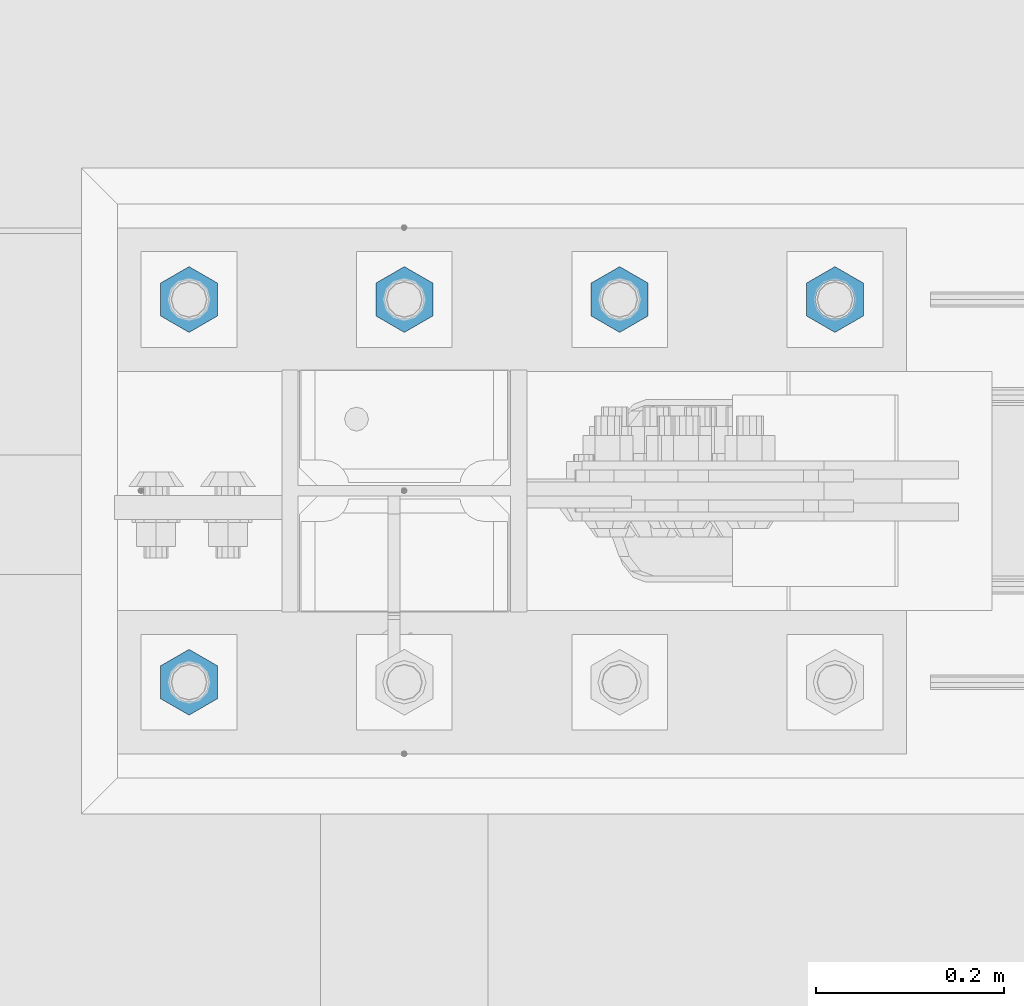
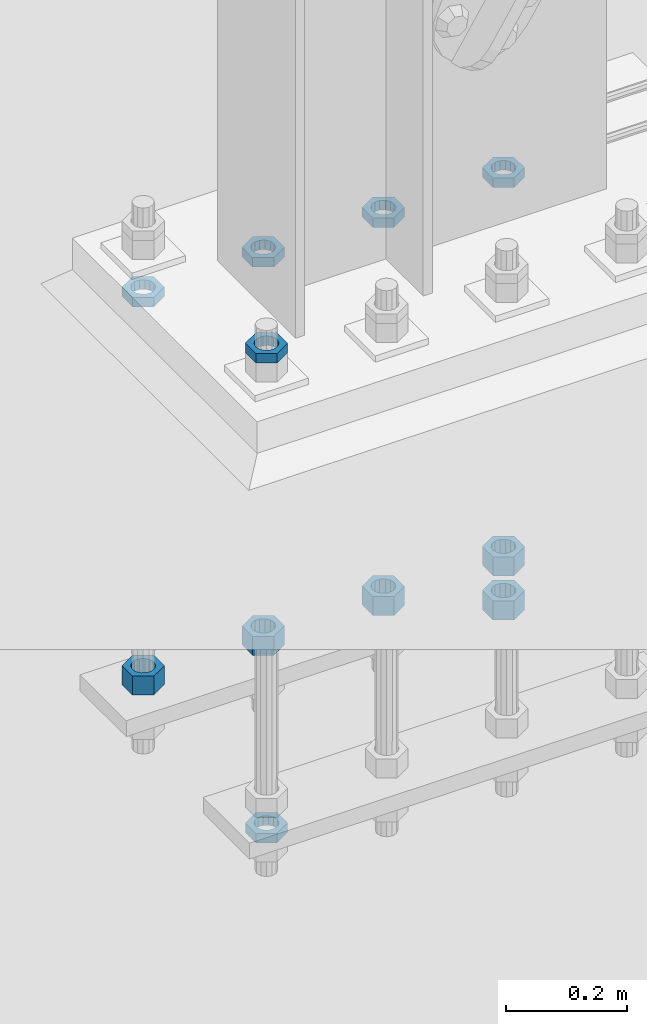
# One storey, part 2912 of 3843: 11 beams, 1 element without a shape of its own.
"""IFC2X3 building model written with IfcOpenShell, lengths in millimetres."""

from ifc_helpers import new_model, si_unit, frame, origin_with_axes, place, context, subcontext, project, spatial, faceted_brep, material, type_object, element, aggregate, save


model = new_model("IFC2X3")

# Units and contexts
model_context = context("Model", 3, precision=1e-05, world=origin_with_axes())
body_context = subcontext(model_context, "Body", "Model", "MODEL_VIEW")
ifc_project = project(units=[si_unit("LENGTHUNIT", "METRE", prefix="MILLI"), si_unit("AREAUNIT", "SQUARE_METRE"), si_unit("VOLUMEUNIT", "CUBIC_METRE"), si_unit("MASSUNIT", "GRAM", prefix="KILO"), si_unit("TIMEUNIT", "SECOND"), si_unit("PLANEANGLEUNIT", "RADIAN"), si_unit("SOLIDANGLEUNIT", "STERADIAN"), si_unit("THERMODYNAMICTEMPERATUREUNIT", "DEGREE_CELSIUS"), si_unit("LUMINOUSINTENSITYUNIT", "LUMEN")], contexts=[model_context])

# Site, building, storey
site_placement = place(None, origin_with_axes())
site = spatial("IfcSite", under=ifc_project, at=site_placement, CompositionType="ELEMENT")
building_placement = place(site_placement, origin_with_axes())
building = spatial("IfcBuilding", under=site, at=building_placement, Name="Undefined", CompositionType="ELEMENT")
storey_placement = place(building_placement, origin_with_axes())
storey = spatial("IfcBuildingStorey", under=building, at=storey_placement, Name="Undefined", CompositionType="ELEMENT", Elevation=0.0)

# Assembly, beams
assembly_placement = place(storey_placement, origin_with_axes())
assembly = element("IfcElementAssembly", 1, at=assembly_placement, inside=storey, Name="TEMPLATE", AssemblyPlace="NOTDEFINED", PredefinedType="RIGID_FRAME")
ifc_material = material(Name="STEEL/A572-50")
beam_type_1 = type_object("IfcBeamType", Name="1-1/2_HEAVY_HEX_NUT", PredefinedType="NOTDEFINED")
beam_1_placement = place(assembly_placement, frame((23317.1999804674, 104762.3, 29298.9), z_axis=(-1.0, 0.0, 0.0), x_axis=(0.0, 0.0, -1.0)))
beam_1 = element("IfcBeam", 2, at=beam_1_placement, type_object=beam_type_1, material=ifc_material, Name="NUT", ObjectType="1-1/2_HEAVY_HEX_NUT", context=body_context, shape_type="Brep", body=[
    faceted_brep([(0.0, -34.9199981689453, 0.0), (0.0, -17.4599990844727, -30.25), (38.0999999999985, -17.4599990844727, -30.25), (38.0999999999985, -34.9199981689453, 0.0), (0.0, 17.4599990844727, -30.25), (38.0999999999985, 17.4599990844727, -30.25), (0.0, 34.9199981689453, 0.0), (38.0999999999985, 34.9199981689453, 0.0), (0.0, 17.4599990844727, 30.25), (38.0999999999985, 17.4599990844727, 30.25), (0.0, -17.4599990844727, 30.25), (38.0999999999985, -17.4599990844727, 30.25), (0.0, 0.0, 20.6399993896484), (0.0, 8.9553601105581, 18.5959968835959), (38.0999999999985, 8.9553601105581, 18.5959968835959), (38.0999999999985, 0.0, 20.6399993896484), (0.0, 16.1370013209525, 12.8688291298167), (38.0999999999985, 16.1370013209525, 12.8688291298167), (0.0, 20.1225115123816, 4.59283194104501), (38.0999999999985, 20.1225115123816, 4.59283194104501), (0.0, 20.1225115123816, -4.59283194104501), (38.0999999999985, 20.1225115123816, -4.59283194104501), (0.0, 16.1370013209525, -12.8688291298167), (38.0999999999985, 16.1370013209525, -12.8688291298167), (0.0, 8.9553601105581, -18.5959968835959), (38.0999999999985, 8.9553601105581, -18.5959968835959), (0.0, 0.0, -20.6399993896484), (38.0999999999985, 0.0, -20.6399993896484), (0.0, -8.9553601105581, -18.5959968835959), (38.0999999999985, -8.9553601105581, -18.5959968835959), (0.0, -16.1370013209525, -12.8688291298167), (38.0999999999985, -16.1370013209525, -12.8688291298167), (0.0, -20.1225115123816, -4.59283194104501), (38.0999999999985, -20.1225115123816, -4.59283194104501), (0.0, -20.1225115123816, 4.59283194104501), (38.0999999999985, -20.1225115123816, 4.59283194104501), (0.0, -16.1370013209525, 12.8688291298167), (38.0999999999985, -16.1370013209525, 12.8688291298167), (0.0, -8.9553601105581, 18.5959968835959), (38.0999999999985, -8.9553601105581, 18.5959968835959)], [[[0, 1, 2, 3]], [[1, 4, 5, 2]], [[4, 6, 7, 5]], [[6, 8, 9, 7]], [[8, 10, 11, 9]], [[10, 0, 3, 11]], [[12, 13, 14, 15]], [[13, 16, 17, 14]], [[16, 18, 19, 17]], [[18, 20, 21, 19]], [[20, 22, 23, 21]], [[22, 24, 25, 23]], [[24, 26, 27, 25]], [[26, 28, 29, 27]], [[28, 30, 31, 29]], [[30, 32, 33, 31]], [[32, 34, 35, 33]], [[34, 36, 37, 35]], [[36, 38, 39, 37]], [[38, 12, 15, 39]], [[5, 7, 9, 11, 3, 2], [17, 19, 21, 23, 25, 27, 29, 31, 33, 35, 37, 39, 15, 14]], [[10, 8, 6, 4, 1, 0], [38, 36, 34, 32, 30, 28, 26, 24, 22, 20, 18, 16, 13, 12]]]),
])
beam_2_placement = place(assembly_placement, frame((23088.5999804674, 104762.3, 29298.9), z_axis=(-1.0, 0.0, 0.0), x_axis=(0.0, 0.0, -1.0)))
beam_2 = element("IfcBeam", 3, at=beam_2_placement, type_object=beam_type_1, material=ifc_material, Name="NUT", ObjectType="1-1/2_HEAVY_HEX_NUT", context=body_context, shape_type="Brep", body=[
    faceted_brep([(0.0, -34.9199981689453, 0.0), (0.0, -17.4599990844727, -30.25), (38.0999999999985, -17.4599990844727, -30.25), (38.0999999999985, -34.9199981689453, 0.0), (0.0, 17.4599990844727, -30.25), (38.0999999999985, 17.4599990844727, -30.25), (0.0, 34.9199981689453, 0.0), (38.0999999999985, 34.9199981689453, 0.0), (0.0, 17.4599990844727, 30.25), (38.0999999999985, 17.4599990844727, 30.25), (0.0, -17.4599990844727, 30.25), (38.0999999999985, -17.4599990844727, 30.25), (0.0, 0.0, 20.6399993896484), (0.0, 8.9553601105581, 18.5959968835959), (38.0999999999985, 8.9553601105581, 18.5959968835959), (38.0999999999985, 0.0, 20.6399993896484), (0.0, 16.1370013209525, 12.8688291298167), (38.0999999999985, 16.1370013209525, 12.8688291298167), (0.0, 20.1225115123816, 4.59283194104501), (38.0999999999985, 20.1225115123816, 4.59283194104501), (0.0, 20.1225115123816, -4.59283194104501), (38.0999999999985, 20.1225115123816, -4.59283194104501), (0.0, 16.1370013209525, -12.8688291298167), (38.0999999999985, 16.1370013209525, -12.8688291298167), (0.0, 8.9553601105581, -18.5959968835959), (38.0999999999985, 8.9553601105581, -18.5959968835959), (0.0, 0.0, -20.6399993896484), (38.0999999999985, 0.0, -20.6399993896484), (0.0, -8.9553601105581, -18.5959968835959), (38.0999999999985, -8.9553601105581, -18.5959968835959), (0.0, -16.1370013209525, -12.8688291298167), (38.0999999999985, -16.1370013209525, -12.8688291298167), (0.0, -20.1225115123816, -4.59283194104501), (38.0999999999985, -20.1225115123816, -4.59283194104501), (0.0, -20.1225115123816, 4.59283194104501), (38.0999999999985, -20.1225115123816, 4.59283194104501), (0.0, -16.1370013209525, 12.8688291298167), (38.0999999999985, -16.1370013209525, 12.8688291298167), (0.0, -8.9553601105581, 18.5959968835959), (38.0999999999985, -8.9553601105581, 18.5959968835959)], [[[0, 1, 2, 3]], [[1, 4, 5, 2]], [[4, 6, 7, 5]], [[6, 8, 9, 7]], [[8, 10, 11, 9]], [[10, 0, 3, 11]], [[12, 13, 14, 15]], [[13, 16, 17, 14]], [[16, 18, 19, 17]], [[18, 20, 21, 19]], [[20, 22, 23, 21]], [[22, 24, 25, 23]], [[24, 26, 27, 25]], [[26, 28, 29, 27]], [[28, 30, 31, 29]], [[30, 32, 33, 31]], [[32, 34, 35, 33]], [[34, 36, 37, 35]], [[36, 38, 39, 37]], [[38, 12, 15, 39]], [[5, 7, 9, 11, 3, 2], [17, 19, 21, 23, 25, 27, 29, 31, 33, 35, 37, 39, 15, 14]], [[10, 8, 6, 4, 1, 0], [38, 36, 34, 32, 30, 28, 26, 24, 22, 20, 18, 16, 13, 12]]]),
])
beam_3_placement = place(assembly_placement, frame((22859.9999804674, 104762.3, 29298.9), z_axis=(-1.0, 0.0, 0.0), x_axis=(0.0, 0.0, -1.0)))
beam_3 = element("IfcBeam", 4, at=beam_3_placement, type_object=beam_type_1, material=ifc_material, Name="NUT", ObjectType="1-1/2_HEAVY_HEX_NUT", context=body_context, shape_type="Brep", body=[
    faceted_brep([(0.0, -34.9199981689453, 0.0), (0.0, -17.4599990844727, -30.25), (38.0999999999985, -17.4599990844727, -30.25), (38.0999999999985, -34.9199981689453, 0.0), (0.0, 17.4599990844727, -30.25), (38.0999999999985, 17.4599990844727, -30.25), (0.0, 34.9199981689453, 0.0), (38.0999999999985, 34.9199981689453, 0.0), (0.0, 17.4599990844727, 30.25), (38.0999999999985, 17.4599990844727, 30.25), (0.0, -17.4599990844727, 30.25), (38.0999999999985, -17.4599990844727, 30.25), (0.0, 0.0, 20.6399993896484), (0.0, 8.9553601105581, 18.5959968835959), (38.0999999999985, 8.9553601105581, 18.5959968835959), (38.0999999999985, 0.0, 20.6399993896484), (0.0, 16.1370013209525, 12.8688291298167), (38.0999999999985, 16.1370013209525, 12.8688291298167), (0.0, 20.1225115123816, 4.59283194104501), (38.0999999999985, 20.1225115123816, 4.59283194104501), (0.0, 20.1225115123816, -4.59283194104501), (38.0999999999985, 20.1225115123816, -4.59283194104501), (0.0, 16.1370013209525, -12.8688291298167), (38.0999999999985, 16.1370013209525, -12.8688291298167), (0.0, 8.9553601105581, -18.5959968835959), (38.0999999999985, 8.9553601105581, -18.5959968835959), (0.0, 0.0, -20.6399993896484), (38.0999999999985, 0.0, -20.6399993896484), (0.0, -8.9553601105581, -18.5959968835959), (38.0999999999985, -8.9553601105581, -18.5959968835959), (0.0, -16.1370013209525, -12.8688291298167), (38.0999999999985, -16.1370013209525, -12.8688291298167), (0.0, -20.1225115123816, -4.59283194104501), (38.0999999999985, -20.1225115123816, -4.59283194104501), (0.0, -20.1225115123816, 4.59283194104501), (38.0999999999985, -20.1225115123816, 4.59283194104501), (0.0, -16.1370013209525, 12.8688291298167), (38.0999999999985, -16.1370013209525, 12.8688291298167), (0.0, -8.9553601105581, 18.5959968835959), (38.0999999999985, -8.9553601105581, 18.5959968835959)], [[[0, 1, 2, 3]], [[1, 4, 5, 2]], [[4, 6, 7, 5]], [[6, 8, 9, 7]], [[8, 10, 11, 9]], [[10, 0, 3, 11]], [[12, 13, 14, 15]], [[13, 16, 17, 14]], [[16, 18, 19, 17]], [[18, 20, 21, 19]], [[20, 22, 23, 21]], [[22, 24, 25, 23]], [[24, 26, 27, 25]], [[26, 28, 29, 27]], [[28, 30, 31, 29]], [[30, 32, 33, 31]], [[32, 34, 35, 33]], [[34, 36, 37, 35]], [[36, 38, 39, 37]], [[38, 12, 15, 39]], [[5, 7, 9, 11, 3, 2], [17, 19, 21, 23, 25, 27, 29, 31, 33, 35, 37, 39, 15, 14]], [[10, 8, 6, 4, 1, 0], [38, 36, 34, 32, 30, 28, 26, 24, 22, 20, 18, 16, 13, 12]]]),
])
beam_4_placement = place(assembly_placement, frame((22631.3999804674, 104762.3, 29298.9), z_axis=(-1.0, 0.0, 0.0), x_axis=(0.0, 0.0, -1.0)))
beam_4 = element("IfcBeam", 5, at=beam_4_placement, type_object=beam_type_1, material=ifc_material, Name="NUT", ObjectType="1-1/2_HEAVY_HEX_NUT", context=body_context, shape_type="Brep", body=[
    faceted_brep([(0.0, -34.9199981689453, 0.0), (0.0, -17.4599990844727, -30.25), (38.0999999999985, -17.4599990844727, -30.25), (38.0999999999985, -34.9199981689453, 0.0), (0.0, 17.4599990844727, -30.25), (38.0999999999985, 17.4599990844727, -30.25), (0.0, 34.9199981689453, 0.0), (38.0999999999985, 34.9199981689453, 0.0), (0.0, 17.4599990844727, 30.25), (38.0999999999985, 17.4599990844727, 30.25), (0.0, -17.4599990844727, 30.25), (38.0999999999985, -17.4599990844727, 30.25), (0.0, 0.0, 20.6399993896484), (0.0, 8.9553601105581, 18.5959968835959), (38.0999999999985, 8.9553601105581, 18.5959968835959), (38.0999999999985, 0.0, 20.6399993896484), (0.0, 16.1370013209525, 12.8688291298167), (38.0999999999985, 16.1370013209525, 12.8688291298167), (0.0, 20.1225115123816, 4.59283194104501), (38.0999999999985, 20.1225115123816, 4.59283194104501), (0.0, 20.1225115123816, -4.59283194104501), (38.0999999999985, 20.1225115123816, -4.59283194104501), (0.0, 16.1370013209525, -12.8688291298167), (38.0999999999985, 16.1370013209525, -12.8688291298167), (0.0, 8.9553601105581, -18.5959968835959), (38.0999999999985, 8.9553601105581, -18.5959968835959), (0.0, 0.0, -20.6399993896484), (38.0999999999985, 0.0, -20.6399993896484), (0.0, -8.9553601105581, -18.5959968835959), (38.0999999999985, -8.9553601105581, -18.5959968835959), (0.0, -16.1370013209525, -12.8688291298167), (38.0999999999985, -16.1370013209525, -12.8688291298167), (0.0, -20.1225115123816, -4.59283194104501), (38.0999999999985, -20.1225115123816, -4.59283194104501), (0.0, -20.1225115123816, 4.59283194104501), (38.0999999999985, -20.1225115123816, 4.59283194104501), (0.0, -16.1370013209525, 12.8688291298167), (38.0999999999985, -16.1370013209525, 12.8688291298167), (0.0, -8.9553601105581, 18.5959968835959), (38.0999999999985, -8.9553601105581, 18.5959968835959)], [[[0, 1, 2, 3]], [[1, 4, 5, 2]], [[4, 6, 7, 5]], [[6, 8, 9, 7]], [[8, 10, 11, 9]], [[10, 0, 3, 11]], [[12, 13, 14, 15]], [[13, 16, 17, 14]], [[16, 18, 19, 17]], [[18, 20, 21, 19]], [[20, 22, 23, 21]], [[22, 24, 25, 23]], [[24, 26, 27, 25]], [[26, 28, 29, 27]], [[28, 30, 31, 29]], [[30, 32, 33, 31]], [[32, 34, 35, 33]], [[34, 36, 37, 35]], [[36, 38, 39, 37]], [[38, 12, 15, 39]], [[5, 7, 9, 11, 3, 2], [17, 19, 21, 23, 25, 27, 29, 31, 33, 35, 37, 39, 15, 14]], [[10, 8, 6, 4, 1, 0], [38, 36, 34, 32, 30, 28, 26, 24, 22, 20, 18, 16, 13, 12]]]),
])
beam_5_placement = place(assembly_placement, frame((23317.1999804674, 104762.3, 29210.0), z_axis=(-1.0, 0.0, 0.0), x_axis=(0.0, 0.0, -1.0)))
beam_5 = element("IfcBeam", 6, at=beam_5_placement, type_object=beam_type_1, material=ifc_material, Name="NUT", ObjectType="1-1/2_HEAVY_HEX_NUT", context=body_context, shape_type="Brep", body=[
    faceted_brep([(0.0, -34.9199981689453, 0.0), (0.0, -17.4599990844727, -30.25), (38.0999999999985, -17.4599990844727, -30.25), (38.0999999999985, -34.9199981689453, 0.0), (0.0, 17.4599990844727, -30.25), (38.0999999999985, 17.4599990844727, -30.25), (0.0, 34.9199981689453, 0.0), (38.0999999999985, 34.9199981689453, 0.0), (0.0, 17.4599990844727, 30.25), (38.0999999999985, 17.4599990844727, 30.25), (0.0, -17.4599990844727, 30.25), (38.0999999999985, -17.4599990844727, 30.25), (0.0, 0.0, 20.6399993896484), (0.0, 8.9553601105581, 18.5959968835959), (38.0999999999985, 8.9553601105581, 18.5959968835959), (38.0999999999985, 0.0, 20.6399993896484), (0.0, 16.1370013209525, 12.8688291298167), (38.0999999999985, 16.1370013209525, 12.8688291298167), (0.0, 20.1225115123816, 4.59283194104501), (38.0999999999985, 20.1225115123816, 4.59283194104501), (0.0, 20.1225115123816, -4.59283194104501), (38.0999999999985, 20.1225115123816, -4.59283194104501), (0.0, 16.1370013209525, -12.8688291298167), (38.0999999999985, 16.1370013209525, -12.8688291298167), (0.0, 8.9553601105581, -18.5959968835959), (38.0999999999985, 8.9553601105581, -18.5959968835959), (0.0, 0.0, -20.6399993896484), (38.0999999999985, 0.0, -20.6399993896484), (0.0, -8.9553601105581, -18.5959968835959), (38.0999999999985, -8.9553601105581, -18.5959968835959), (0.0, -16.1370013209525, -12.8688291298167), (38.0999999999985, -16.1370013209525, -12.8688291298167), (0.0, -20.1225115123816, -4.59283194104501), (38.0999999999985, -20.1225115123816, -4.59283194104501), (0.0, -20.1225115123816, 4.59283194104501), (38.0999999999985, -20.1225115123816, 4.59283194104501), (0.0, -16.1370013209525, 12.8688291298167), (38.0999999999985, -16.1370013209525, 12.8688291298167), (0.0, -8.9553601105581, 18.5959968835959), (38.0999999999985, -8.9553601105581, 18.5959968835959)], [[[0, 1, 2, 3]], [[1, 4, 5, 2]], [[4, 6, 7, 5]], [[6, 8, 9, 7]], [[8, 10, 11, 9]], [[10, 0, 3, 11]], [[12, 13, 14, 15]], [[13, 16, 17, 14]], [[16, 18, 19, 17]], [[18, 20, 21, 19]], [[20, 22, 23, 21]], [[22, 24, 25, 23]], [[24, 26, 27, 25]], [[26, 28, 29, 27]], [[28, 30, 31, 29]], [[30, 32, 33, 31]], [[32, 34, 35, 33]], [[34, 36, 37, 35]], [[36, 38, 39, 37]], [[38, 12, 15, 39]], [[5, 7, 9, 11, 3, 2], [17, 19, 21, 23, 25, 27, 29, 31, 33, 35, 37, 39, 15, 14]], [[10, 8, 6, 4, 1, 0], [38, 36, 34, 32, 30, 28, 26, 24, 22, 20, 18, 16, 13, 12]]]),
])
beam_type_2 = type_object("IfcBeamType", Name="1-1/2_HALF_NUT", PredefinedType="NOTDEFINED")
beam_6_placement = place(assembly_placement, frame((23317.199987793, 104762.3, 30060.9), z_axis=(-1.0, 0.0, 0.0), x_axis=(0.0, 0.0, -1.0)))
beam_6 = element("IfcBeam", 7, at=beam_6_placement, type_object=beam_type_2, material=ifc_material, Name="NUT", ObjectType="1-1/2_HALF_NUT", context=body_context, shape_type="Brep", body=[
    faceted_brep([(0.0, -34.9199981689453, 0.0), (0.0, -17.4599990844727, -30.25), (19.0500000000029, -17.4599990844727, -30.25), (19.0500000000029, -34.9199981689453, 0.0), (0.0, 17.4599990844727, -30.25), (19.0500000000029, 17.4599990844727, -30.25), (0.0, 34.9199981689453, 0.0), (19.0500000000029, 34.9199981689453, 0.0), (0.0, 17.4599990844727, 30.25), (19.0500000000029, 17.4599990844727, 30.25), (0.0, -17.4599990844727, 30.25), (19.0500000000029, -17.4599990844727, 30.25), (0.0, 0.0, 20.6399993896484), (0.0, 8.9553601105581, 18.5959968835959), (19.0500000000029, 8.95536011056538, 18.5959968835959), (19.0500000000029, 0.0, 20.6399993896484), (0.0, 16.1370013209525, 12.8688291298167), (19.0500000000029, 16.1370013209489, 12.8688291298167), (0.0, 20.1225115123816, 4.59283194104501), (19.0500000000029, 20.1225115123852, 4.59283194104501), (0.0, 20.1225115123816, -4.59283194104501), (19.0500000000029, 20.1225115123852, -4.59283194104501), (0.0, 16.1370013209525, -12.8688291298167), (19.0500000000029, 16.1370013209489, -12.8688291298167), (0.0, 8.9553601105581, -18.5959968835959), (19.0500000000029, 8.95536011056538, -18.5959968835959), (0.0, 0.0, -20.6399993896484), (19.0500000000029, 0.0, -20.6399993896484), (0.0, -8.9553601105581, -18.5959968835959), (19.0500000000029, -8.95536011056538, -18.5959968835959), (0.0, -16.1370013209525, -12.8688291298167), (19.0500000000029, -16.1370013209489, -12.8688291298167), (0.0, -20.1225115123816, -4.59283194104501), (19.0500000000029, -20.1225115123852, -4.59283194104501), (0.0, -20.1225115123816, 4.59283194104501), (19.0500000000029, -20.1225115123852, 4.59283194104501), (0.0, -16.1370013209525, 12.8688291298167), (19.0500000000029, -16.1370013209489, 12.8688291298167), (0.0, -8.9553601105581, 18.5959968835959), (19.0500000000029, -8.95536011056538, 18.5959968835959)], [[[0, 1, 2, 3]], [[1, 4, 5, 2]], [[4, 6, 7, 5]], [[6, 8, 9, 7]], [[8, 10, 11, 9]], [[10, 0, 3, 11]], [[12, 13, 14, 15]], [[13, 16, 17, 14]], [[16, 18, 19, 17]], [[18, 20, 21, 19]], [[20, 22, 23, 21]], [[22, 24, 25, 23]], [[24, 26, 27, 25]], [[26, 28, 29, 27]], [[28, 30, 31, 29]], [[30, 32, 33, 31]], [[32, 34, 35, 33]], [[34, 36, 37, 35]], [[36, 38, 39, 37]], [[38, 12, 15, 39]], [[5, 7, 9, 11, 3, 2], [17, 19, 21, 23, 25, 27, 29, 31, 33, 35, 37, 39, 15, 14]], [[10, 8, 6, 4, 1, 0], [38, 36, 34, 32, 30, 28, 26, 24, 22, 20, 18, 16, 13, 12]]]),
])
beam_7_placement = place(assembly_placement, frame((23088.599987793, 104762.3, 30060.9), z_axis=(-1.0, 0.0, 0.0), x_axis=(0.0, 0.0, -1.0)))
beam_7 = element("IfcBeam", 8, at=beam_7_placement, type_object=beam_type_2, material=ifc_material, Name="NUT", ObjectType="1-1/2_HALF_NUT", context=body_context, shape_type="Brep", body=[
    faceted_brep([(0.0, -34.9199981689453, 0.0), (0.0, -17.4599990844727, -30.25), (19.0500000000029, -17.4599990844727, -30.25), (19.0500000000029, -34.9199981689453, 0.0), (0.0, 17.4599990844727, -30.25), (19.0500000000029, 17.4599990844727, -30.25), (0.0, 34.9199981689453, 0.0), (19.0500000000029, 34.9199981689453, 0.0), (0.0, 17.4599990844727, 30.25), (19.0500000000029, 17.4599990844727, 30.25), (0.0, -17.4599990844727, 30.25), (19.0500000000029, -17.4599990844727, 30.25), (0.0, 0.0, 20.6399993896484), (0.0, 8.9553601105581, 18.5959968835959), (19.0500000000029, 8.95536011056538, 18.5959968835959), (19.0500000000029, 0.0, 20.6399993896484), (0.0, 16.1370013209525, 12.8688291298167), (19.0500000000029, 16.1370013209489, 12.8688291298167), (0.0, 20.1225115123816, 4.59283194104501), (19.0500000000029, 20.1225115123852, 4.59283194104501), (0.0, 20.1225115123816, -4.59283194104501), (19.0500000000029, 20.1225115123852, -4.59283194104501), (0.0, 16.1370013209525, -12.8688291298167), (19.0500000000029, 16.1370013209489, -12.8688291298167), (0.0, 8.9553601105581, -18.5959968835959), (19.0500000000029, 8.95536011056538, -18.5959968835959), (0.0, 0.0, -20.6399993896484), (19.0500000000029, 0.0, -20.6399993896484), (0.0, -8.9553601105581, -18.5959968835959), (19.0500000000029, -8.95536011056538, -18.5959968835959), (0.0, -16.1370013209525, -12.8688291298167), (19.0500000000029, -16.1370013209489, -12.8688291298167), (0.0, -20.1225115123816, -4.59283194104501), (19.0500000000029, -20.1225115123852, -4.59283194104501), (0.0, -20.1225115123816, 4.59283194104501), (19.0500000000029, -20.1225115123852, 4.59283194104501), (0.0, -16.1370013209525, 12.8688291298167), (19.0500000000029, -16.1370013209489, 12.8688291298167), (0.0, -8.9553601105581, 18.5959968835959), (19.0500000000029, -8.95536011056538, 18.5959968835959)], [[[0, 1, 2, 3]], [[1, 4, 5, 2]], [[4, 6, 7, 5]], [[6, 8, 9, 7]], [[8, 10, 11, 9]], [[10, 0, 3, 11]], [[12, 13, 14, 15]], [[13, 16, 17, 14]], [[16, 18, 19, 17]], [[18, 20, 21, 19]], [[20, 22, 23, 21]], [[22, 24, 25, 23]], [[24, 26, 27, 25]], [[26, 28, 29, 27]], [[28, 30, 31, 29]], [[30, 32, 33, 31]], [[32, 34, 35, 33]], [[34, 36, 37, 35]], [[36, 38, 39, 37]], [[38, 12, 15, 39]], [[5, 7, 9, 11, 3, 2], [17, 19, 21, 23, 25, 27, 29, 31, 33, 35, 37, 39, 15, 14]], [[10, 8, 6, 4, 1, 0], [38, 36, 34, 32, 30, 28, 26, 24, 22, 20, 18, 16, 13, 12]]]),
])
beam_8_placement = place(assembly_placement, frame((22859.999987793, 104762.3, 30060.9), z_axis=(-1.0, 0.0, 0.0), x_axis=(0.0, 0.0, -1.0)))
beam_8 = element("IfcBeam", 9, at=beam_8_placement, type_object=beam_type_2, material=ifc_material, Name="NUT", ObjectType="1-1/2_HALF_NUT", context=body_context, shape_type="Brep", body=[
    faceted_brep([(0.0, -34.9199981689453, 0.0), (0.0, -17.4599990844727, -30.25), (19.0500000000029, -17.4599990844727, -30.25), (19.0500000000029, -34.9199981689453, 0.0), (0.0, 17.4599990844727, -30.25), (19.0500000000029, 17.4599990844727, -30.25), (0.0, 34.9199981689453, 0.0), (19.0500000000029, 34.9199981689453, 0.0), (0.0, 17.4599990844727, 30.25), (19.0500000000029, 17.4599990844727, 30.25), (0.0, -17.4599990844727, 30.25), (19.0500000000029, -17.4599990844727, 30.25), (0.0, 0.0, 20.6399993896484), (0.0, 8.9553601105581, 18.5959968835959), (19.0500000000029, 8.95536011056538, 18.5959968835959), (19.0500000000029, 0.0, 20.6399993896484), (0.0, 16.1370013209525, 12.8688291298167), (19.0500000000029, 16.1370013209489, 12.8688291298167), (0.0, 20.1225115123816, 4.59283194104501), (19.0500000000029, 20.1225115123852, 4.59283194104501), (0.0, 20.1225115123816, -4.59283194104501), (19.0500000000029, 20.1225115123852, -4.59283194104501), (0.0, 16.1370013209525, -12.8688291298167), (19.0500000000029, 16.1370013209489, -12.8688291298167), (0.0, 8.9553601105581, -18.5959968835959), (19.0500000000029, 8.95536011056538, -18.5959968835959), (0.0, 0.0, -20.6399993896484), (19.0500000000029, 0.0, -20.6399993896484), (0.0, -8.9553601105581, -18.5959968835959), (19.0500000000029, -8.95536011056538, -18.5959968835959), (0.0, -16.1370013209525, -12.8688291298167), (19.0500000000029, -16.1370013209489, -12.8688291298167), (0.0, -20.1225115123816, -4.59283194104501), (19.0500000000029, -20.1225115123852, -4.59283194104501), (0.0, -20.1225115123816, 4.59283194104501), (19.0500000000029, -20.1225115123852, 4.59283194104501), (0.0, -16.1370013209525, 12.8688291298167), (19.0500000000029, -16.1370013209489, 12.8688291298167), (0.0, -8.9553601105581, 18.5959968835959), (19.0500000000029, -8.95536011056538, 18.5959968835959)], [[[0, 1, 2, 3]], [[1, 4, 5, 2]], [[4, 6, 7, 5]], [[6, 8, 9, 7]], [[8, 10, 11, 9]], [[10, 0, 3, 11]], [[12, 13, 14, 15]], [[13, 16, 17, 14]], [[16, 18, 19, 17]], [[18, 20, 21, 19]], [[20, 22, 23, 21]], [[22, 24, 25, 23]], [[24, 26, 27, 25]], [[26, 28, 29, 27]], [[28, 30, 31, 29]], [[30, 32, 33, 31]], [[32, 34, 35, 33]], [[34, 36, 37, 35]], [[36, 38, 39, 37]], [[38, 12, 15, 39]], [[5, 7, 9, 11, 3, 2], [17, 19, 21, 23, 25, 27, 29, 31, 33, 35, 37, 39, 15, 14]], [[10, 8, 6, 4, 1, 0], [38, 36, 34, 32, 30, 28, 26, 24, 22, 20, 18, 16, 13, 12]]]),
])
beam_9_placement = place(assembly_placement, frame((22631.399987793, 104762.3, 30060.9), z_axis=(-1.0, 0.0, 0.0), x_axis=(0.0, 0.0, -1.0)))
beam_9 = element("IfcBeam", 10, at=beam_9_placement, type_object=beam_type_2, material=ifc_material, Name="NUT", ObjectType="1-1/2_HALF_NUT", context=body_context, shape_type="Brep", body=[
    faceted_brep([(0.0, -34.9199981689453, 0.0), (0.0, -17.4599990844727, -30.25), (19.0500000000029, -17.4599990844727, -30.25), (19.0500000000029, -34.9199981689453, 0.0), (0.0, 17.4599990844727, -30.25), (19.0500000000029, 17.4599990844727, -30.25), (0.0, 34.9199981689453, 0.0), (19.0500000000029, 34.9199981689453, 0.0), (0.0, 17.4599990844727, 30.25), (19.0500000000029, 17.4599990844727, 30.25), (0.0, -17.4599990844727, 30.25), (19.0500000000029, -17.4599990844727, 30.25), (0.0, 0.0, 20.6399993896484), (0.0, 8.9553601105581, 18.5959968835959), (19.0500000000029, 8.95536011056538, 18.5959968835959), (19.0500000000029, 0.0, 20.6399993896484), (0.0, 16.1370013209525, 12.8688291298167), (19.0500000000029, 16.1370013209489, 12.8688291298167), (0.0, 20.1225115123816, 4.59283194104501), (19.0500000000029, 20.1225115123852, 4.59283194104501), (0.0, 20.1225115123816, -4.59283194104501), (19.0500000000029, 20.1225115123852, -4.59283194104501), (0.0, 16.1370013209525, -12.8688291298167), (19.0500000000029, 16.1370013209489, -12.8688291298167), (0.0, 8.9553601105581, -18.5959968835959), (19.0500000000029, 8.95536011056538, -18.5959968835959), (0.0, 0.0, -20.6399993896484), (19.0500000000029, 0.0, -20.6399993896484), (0.0, -8.9553601105581, -18.5959968835959), (19.0500000000029, -8.95536011056538, -18.5959968835959), (0.0, -16.1370013209525, -12.8688291298167), (19.0500000000029, -16.1370013209489, -12.8688291298167), (0.0, -20.1225115123816, -4.59283194104501), (19.0500000000029, -20.1225115123852, -4.59283194104501), (0.0, -20.1225115123816, 4.59283194104501), (19.0500000000029, -20.1225115123852, 4.59283194104501), (0.0, -16.1370013209525, 12.8688291298167), (19.0500000000029, -16.1370013209489, 12.8688291298167), (0.0, -8.9553601105581, 18.5959968835959), (19.0500000000029, -8.95536011056538, 18.5959968835959)], [[[0, 1, 2, 3]], [[1, 4, 5, 2]], [[4, 6, 7, 5]], [[6, 8, 9, 7]], [[8, 10, 11, 9]], [[10, 0, 3, 11]], [[12, 13, 14, 15]], [[13, 16, 17, 14]], [[16, 18, 19, 17]], [[18, 20, 21, 19]], [[20, 22, 23, 21]], [[22, 24, 25, 23]], [[24, 26, 27, 25]], [[26, 28, 29, 27]], [[28, 30, 31, 29]], [[30, 32, 33, 31]], [[32, 34, 35, 33]], [[34, 36, 37, 35]], [[36, 38, 39, 37]], [[38, 12, 15, 39]], [[5, 7, 9, 11, 3, 2], [17, 19, 21, 23, 25, 27, 29, 31, 33, 35, 37, 39, 15, 14]], [[10, 8, 6, 4, 1, 0], [38, 36, 34, 32, 30, 28, 26, 24, 22, 20, 18, 16, 13, 12]]]),
])
beam_10_placement = place(assembly_placement, frame((22631.4000244154, 104355.9, 30194.25), z_axis=(1.0, 0.0, 0.0), x_axis=(0.0, 0.0, -1.0)))
beam_10 = element("IfcBeam", 11, at=beam_10_placement, type_object=beam_type_2, material=ifc_material, Name="NUT", ObjectType="1-1/2_HALF_NUT", context=body_context, shape_type="Brep", body=[
    faceted_brep([(0.0, -34.9199981689453, 0.0), (0.0, -17.4599990844727, -30.25), (19.0500000000029, -17.4599990844727, -30.25), (19.0500000000029, -34.9199981689453, 0.0), (0.0, 17.4599990844727, -30.25), (19.0500000000029, 17.4599990844727, -30.25), (0.0, 34.9199981689453, 0.0), (19.0500000000029, 34.9199981689453, 0.0), (0.0, 17.4599990844727, 30.25), (19.0500000000029, 17.4599990844727, 30.25), (0.0, -17.4599990844727, 30.25), (19.0500000000029, -17.4599990844727, 30.25), (0.0, 0.0, 20.6399993896484), (0.0, 8.9553601105581, 18.5959968835959), (19.0500000000029, 8.95536011056538, 18.5959968835959), (19.0500000000029, 0.0, 20.6399993896484), (0.0, 16.1370013209525, 12.8688291298167), (19.0500000000029, 16.1370013209489, 12.8688291298167), (0.0, 20.1225115123816, 4.59283194104501), (19.0500000000029, 20.1225115123852, 4.59283194104501), (0.0, 20.1225115123816, -4.59283194104501), (19.0500000000029, 20.1225115123852, -4.59283194104501), (0.0, 16.1370013209525, -12.8688291298167), (19.0500000000029, 16.1370013209489, -12.8688291298167), (0.0, 8.9553601105581, -18.5959968835959), (19.0500000000029, 8.95536011056538, -18.5959968835959), (0.0, 0.0, -20.6399993896484), (19.0500000000029, 0.0, -20.6399993896484), (0.0, -8.9553601105581, -18.5959968835959), (19.0500000000029, -8.95536011056538, -18.5959968835959), (0.0, -16.1370013209525, -12.8688291298167), (19.0500000000029, -16.1370013209489, -12.8688291298167), (0.0, -20.1225115123816, -4.59283194104501), (19.0500000000029, -20.1225115123852, -4.59283194104501), (0.0, -20.1225115123816, 4.59283194104501), (19.0500000000029, -20.1225115123852, 4.59283194104501), (0.0, -16.1370013209525, 12.8688291298167), (19.0500000000029, -16.1370013209489, 12.8688291298167), (0.0, -8.9553601105581, 18.5959968835959), (19.0500000000029, -8.95536011056538, 18.5959968835959)], [[[0, 1, 2, 3]], [[1, 4, 5, 2]], [[4, 6, 7, 5]], [[6, 8, 9, 7]], [[8, 10, 11, 9]], [[10, 0, 3, 11]], [[12, 13, 14, 15]], [[13, 16, 17, 14]], [[16, 18, 19, 17]], [[18, 20, 21, 19]], [[20, 22, 23, 21]], [[22, 24, 25, 23]], [[24, 26, 27, 25]], [[26, 28, 29, 27]], [[28, 30, 31, 29]], [[30, 32, 33, 31]], [[32, 34, 35, 33]], [[34, 36, 37, 35]], [[36, 38, 39, 37]], [[38, 12, 15, 39]], [[5, 7, 9, 11, 3, 2], [17, 19, 21, 23, 25, 27, 29, 31, 33, 35, 37, 39, 15, 14]], [[10, 8, 6, 4, 1, 0], [38, 36, 34, 32, 30, 28, 26, 24, 22, 20, 18, 16, 13, 12]]]),
])
beam_11_placement = place(assembly_placement, frame((22631.4, 104355.9, 29229.05), z_axis=(1.0, 0.0, 0.0), x_axis=(0.0, 0.0, -1.0)))
beam_11 = element("IfcBeam", 12, at=beam_11_placement, type_object=beam_type_2, material=ifc_material, Name="NUT", ObjectType="1-1/2_HALF_NUT", context=body_context, shape_type="Brep", body=[
    faceted_brep([(0.0, -34.9199981689453, 0.0), (0.0, -17.4599990844727, -30.25), (19.0500000000029, -17.4599990844727, -30.25), (19.0500000000029, -34.9199981689453, 0.0), (0.0, 17.4599990844727, -30.25), (19.0500000000029, 17.4599990844727, -30.25), (0.0, 34.9199981689453, 0.0), (19.0500000000029, 34.9199981689453, 0.0), (0.0, 17.4599990844727, 30.25), (19.0500000000029, 17.4599990844727, 30.25), (0.0, -17.4599990844727, 30.25), (19.0500000000029, -17.4599990844727, 30.25), (0.0, 0.0, 20.6399993896484), (0.0, 8.9553601105581, 18.5959968835959), (19.0500000000029, 8.95536011056538, 18.5959968835959), (19.0500000000029, 0.0, 20.6399993896484), (0.0, 16.1370013209525, 12.8688291298167), (19.0500000000029, 16.1370013209489, 12.8688291298167), (0.0, 20.1225115123816, 4.59283194104501), (19.0500000000029, 20.1225115123852, 4.59283194104501), (0.0, 20.1225115123816, -4.59283194104501), (19.0500000000029, 20.1225115123852, -4.59283194104501), (0.0, 16.1370013209525, -12.8688291298167), (19.0500000000029, 16.1370013209489, -12.8688291298167), (0.0, 8.9553601105581, -18.5959968835959), (19.0500000000029, 8.95536011056538, -18.5959968835959), (0.0, 0.0, -20.6399993896484), (19.0500000000029, 0.0, -20.6399993896484), (0.0, -8.9553601105581, -18.5959968835959), (19.0500000000029, -8.95536011056538, -18.5959968835959), (0.0, -16.1370013209525, -12.8688291298167), (19.0500000000029, -16.1370013209489, -12.8688291298167), (0.0, -20.1225115123816, -4.59283194104501), (19.0500000000029, -20.1225115123852, -4.59283194104501), (0.0, -20.1225115123816, 4.59283194104501), (19.0500000000029, -20.1225115123852, 4.59283194104501), (0.0, -16.1370013209525, 12.8688291298167), (19.0500000000029, -16.1370013209489, 12.8688291298167), (0.0, -8.9553601105581, 18.5959968835959), (19.0500000000029, -8.95536011056538, 18.5959968835959)], [[[0, 1, 2, 3]], [[1, 4, 5, 2]], [[4, 6, 7, 5]], [[6, 8, 9, 7]], [[8, 10, 11, 9]], [[10, 0, 3, 11]], [[12, 13, 14, 15]], [[13, 16, 17, 14]], [[16, 18, 19, 17]], [[18, 20, 21, 19]], [[20, 22, 23, 21]], [[22, 24, 25, 23]], [[24, 26, 27, 25]], [[26, 28, 29, 27]], [[28, 30, 31, 29]], [[30, 32, 33, 31]], [[32, 34, 35, 33]], [[34, 36, 37, 35]], [[36, 38, 39, 37]], [[38, 12, 15, 39]], [[5, 7, 9, 11, 3, 2], [17, 19, 21, 23, 25, 27, 29, 31, 33, 35, 37, 39, 15, 14]], [[10, 8, 6, 4, 1, 0], [38, 36, 34, 32, 30, 28, 26, 24, 22, 20, 18, 16, 13, 12]]]),
])
aggregate(assembly, [beam_1, beam_2, beam_3, beam_4, beam_6, beam_7, beam_8, beam_9, beam_5, beam_10, beam_11])

save(model, "model.ifc")
